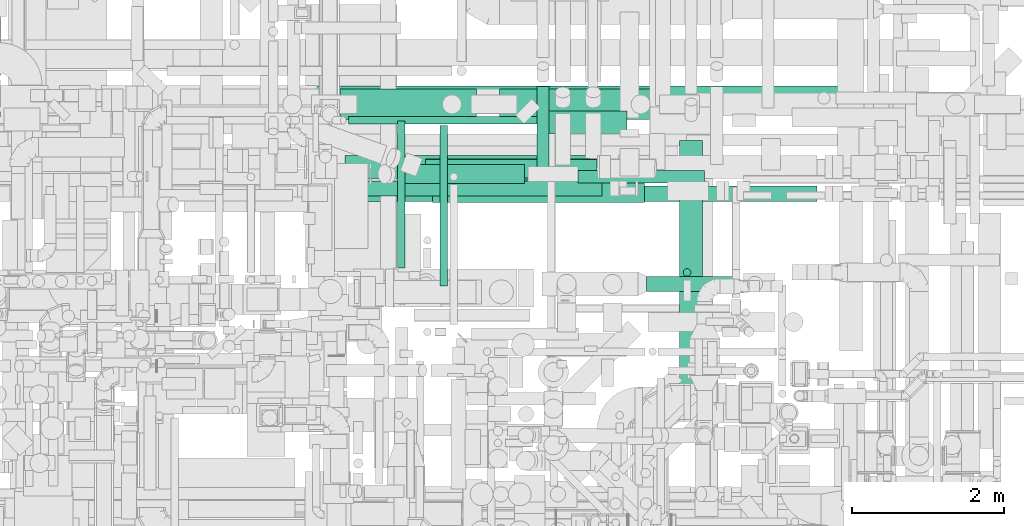
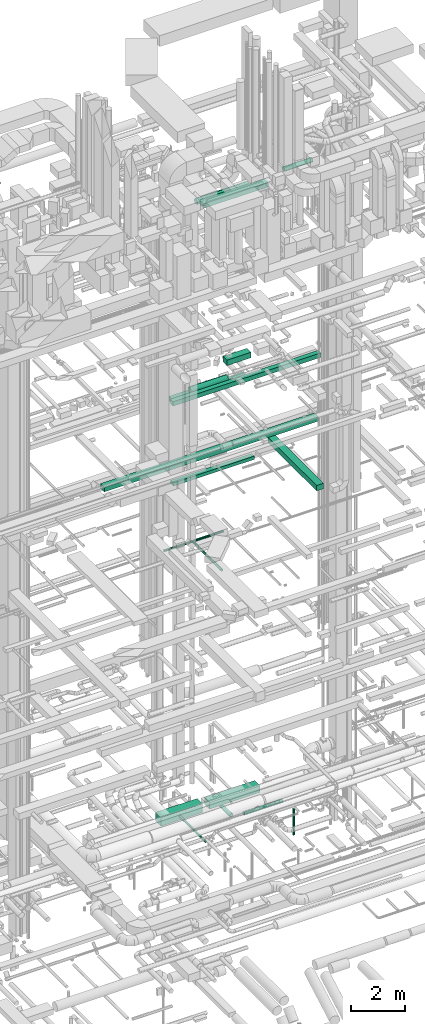
# One storey, part 59 of 337: 18 flow segments.
"""IFC2X3 building model written with IfcOpenShell, lengths in millimetres."""

from ifc_helpers import new_model, entity, si_unit, converted_unit, derived_unit, direction, frame, origin, origin_2d_with_axis, place, context, subcontext, project, spatial, rectangle, circle, extrude, type_object, element, save


model = new_model("IFC2X3")

# Units and contexts
model_context = context("Model", 3, precision=0.01, world=origin(), true_north=direction((6.12303176911189e-17, 1.0)))
body_context = subcontext(model_context, "Body", "Model", "MODEL_VIEW")
ifc_project = project(units=[si_unit("LENGTHUNIT", "METRE", prefix="MILLI"), si_unit("AREAUNIT", "SQUARE_METRE"), si_unit("VOLUMEUNIT", "CUBIC_METRE"), converted_unit("PLANEANGLEUNIT", "DEGREE", entity("IfcRatioMeasure", 0.0174532925199433), si_unit("PLANEANGLEUNIT", "RADIAN"), dimensions=[0, 0, 0, 0, 0, 0, 0]), si_unit("MASSUNIT", "GRAM", prefix="KILO"), derived_unit("MASSDENSITYUNIT", [(si_unit("MASSUNIT", "GRAM", prefix="KILO"), 1), (si_unit("LENGTHUNIT", "METRE"), -3)]), derived_unit("MOMENTOFINERTIAUNIT", [(si_unit("LENGTHUNIT", "METRE"), 4)]), si_unit("TIMEUNIT", "SECOND"), si_unit("FREQUENCYUNIT", "HERTZ"), si_unit("THERMODYNAMICTEMPERATUREUNIT", "DEGREE_CELSIUS"), derived_unit("THERMALTRANSMITTANCEUNIT", [(si_unit("MASSUNIT", "GRAM", prefix="KILO"), 1), (si_unit("THERMODYNAMICTEMPERATUREUNIT", "KELVIN"), -1), (si_unit("TIMEUNIT", "SECOND"), -3)]), derived_unit("VOLUMETRICFLOWRATEUNIT", [(si_unit("LENGTHUNIT", "METRE"), 3), (si_unit("TIMEUNIT", "SECOND"), -1)]), derived_unit("MASSFLOWRATEUNIT", [(si_unit("MASSUNIT", "GRAM", prefix="KILO"), 1), (si_unit("TIMEUNIT", "SECOND"), -1)]), derived_unit("ROTATIONALFREQUENCYUNIT", [(si_unit("TIMEUNIT", "SECOND"), -1)]), si_unit("ELECTRICCURRENTUNIT", "AMPERE"), si_unit("ELECTRICVOLTAGEUNIT", "VOLT"), si_unit("POWERUNIT", "WATT"), si_unit("FORCEUNIT", "NEWTON", prefix="KILO"), si_unit("ILLUMINANCEUNIT", "LUX"), si_unit("LUMINOUSFLUXUNIT", "LUMEN"), si_unit("LUMINOUSINTENSITYUNIT", "CANDELA"), derived_unit("USERDEFINED", [(si_unit("MASSUNIT", "GRAM", prefix="KILO"), -1), (si_unit("LENGTHUNIT", "METRE"), -2), (si_unit("TIMEUNIT", "SECOND"), 3), (si_unit("LUMINOUSFLUXUNIT", "LUMEN"), 1)]), derived_unit("LINEARVELOCITYUNIT", [(si_unit("LENGTHUNIT", "METRE"), 1), (si_unit("TIMEUNIT", "SECOND"), -1)]), si_unit("PRESSUREUNIT", "PASCAL"), derived_unit("USERDEFINED", [(si_unit("LENGTHUNIT", "METRE"), -2), (si_unit("MASSUNIT", "GRAM", prefix="KILO"), 1), (si_unit("TIMEUNIT", "SECOND"), -2)]), derived_unit("LINEARFORCEUNIT", [(si_unit("MASSUNIT", "GRAM", prefix="KILO"), 1), (si_unit("LENGTHUNIT", "METRE"), 1), (si_unit("TIMEUNIT", "SECOND"), -2), (si_unit("LENGTHUNIT", "METRE"), -1)]), derived_unit("PLANARFORCEUNIT", [(si_unit("MASSUNIT", "GRAM", prefix="KILO"), 1), (si_unit("LENGTHUNIT", "METRE"), 1), (si_unit("TIMEUNIT", "SECOND"), -2), (si_unit("LENGTHUNIT", "METRE"), -2)])], contexts=[model_context])

# Site, building, storey
site_placement = place(None, origin())
site = spatial("IfcSite", under=ifc_project, at=site_placement, CompositionType="ELEMENT")
building_placement = place(site_placement, origin())
building = spatial("IfcBuilding", under=site, at=building_placement, CompositionType="ELEMENT")
storey_placement = place(building_placement, origin())
storey = spatial("IfcBuildingStorey", under=building, at=storey_placement, CompositionType="ELEMENT", Elevation=0.0)

# Flow segments
duct_segment_type_1 = type_object("IfcDuctSegmentType", PredefinedType="NOTDEFINED")
flow_segment_1_placement = place(storey_placement, frame((53521.17, 15148.96, -1050.0)))
element("IfcFlowSegment", 1, at=flow_segment_1_placement, inside=storey, type_object=duct_segment_type_1, context=body_context, shape_type="SweptSolid", body=[
    extrude(rectangle(XDim=1794.33030025006, YDim=400.0, at=origin_2d_with_axis()), frame((897.17, 200.0, 0.0)), (0.0, 0.0, 1.0), 400.0),
])
flow_segment_2_placement = place(storey_placement, frame((55615.5, 15148.96, -1000.0)))
element("IfcFlowSegment", 2, at=flow_segment_2_placement, inside=storey, type_object=duct_segment_type_1, context=body_context, shape_type="SweptSolid", body=[
    extrude(rectangle(XDim=2175.17176975001, YDim=400.0, at=origin_2d_with_axis()), frame((1087.59, 200.0, 0.0)), (0.0, 0.0, 1.0), 300.0),
])
flow_segment_3_placement = place(storey_placement, frame((51169.3, 15290.0, 14900.0)))
element("IfcFlowSegment", 3, at=flow_segment_3_placement, inside=storey, type_object=duct_segment_type_1, context=body_context, shape_type="SweptSolid", body=[
    extrude(rectangle(XDim=9217.88273742502, YDim=300.000000000001, at=origin_2d_with_axis()), frame((4608.94, 150.0, 0.0), z_axis=(0.0, 0.0, 1.0), x_axis=(-1.0, 0.0, 0.0)), (0.0, 0.0, 1.0), 200.000000000002),
])
flow_segment_4_placement = place(storey_placement, frame((53470.19, 14143.91, 15050.0)))
element("IfcFlowSegment", 4, at=flow_segment_4_placement, inside=storey, type_object=duct_segment_type_1, context=body_context, shape_type="SweptSolid", body=[
    extrude(rectangle(XDim=3488.48123509233, YDim=200.0, at=origin_2d_with_axis()), frame((1744.24, 100.0, 0.0), z_axis=(0.0, 0.0, 1.0), x_axis=(-1.0, 0.0, 0.0)), (0.0, 0.0, 1.0), 150.000000000001),
])
flow_segment_5_placement = place(storey_placement, frame((57977.28, 11265.63, 15000.0)))
element("IfcFlowSegment", 5, at=flow_segment_5_placement, inside=storey, type_object=duct_segment_type_1, context=body_context, shape_type="SweptSolid", body=[
    extrude(rectangle(XDim=3607.45757233171, YDim=300.000000000001, at=origin_2d_with_axis()), frame((150.0, 1803.73, 0.0), z_axis=(0.0, 0.0, 1.0), x_axis=(0.0, -1.0, 0.0)), (0.0, 0.0, 1.0), 249.999999999999),
])
flow_segment_6_placement = place(storey_placement, frame((53417.53, 14075.53, 18750.0)))
element("IfcFlowSegment", 6, at=flow_segment_6_placement, inside=storey, type_object=duct_segment_type_1, context=body_context, shape_type="SweptSolid", body=[
    extrude(rectangle(XDim=6362.55047582083, YDim=200.0, at=origin_2d_with_axis()), frame((3181.28, 100.0, 0.0)), (0.0, 0.0, 1.0), 200.000000000002),
])
flow_segment_7_placement = place(storey_placement, frame((56252.92, 14964.34, 19059.58)))
element("IfcFlowSegment", 7, at=flow_segment_7_placement, inside=storey, type_object=duct_segment_type_1, context=body_context, shape_type="SweptSolid", body=[
    extrude(rectangle(XDim=1036.51344696079, YDim=300.000000000001, at=origin_2d_with_axis()), frame((518.26, 150.0, 0.0), z_axis=(0.0, 0.0, 1.0), x_axis=(-1.0, 0.0, 0.0)), (0.0, 0.0, 1.0), 249.999999999999),
])
flow_segment_8_placement = place(storey_placement, frame((53590.57, 14375.32, 18577.01)))
element("IfcFlowSegment", 8, at=flow_segment_8_placement, inside=storey, type_object=duct_segment_type_1, context=body_context, shape_type="SweptSolid", body=[
    extrude(rectangle(XDim=3205.80194846593, YDim=299.999999999999, at=origin_2d_with_axis()), frame((1602.9, 150.0, 0.0), z_axis=(0.0, 0.0, 1.0), x_axis=(-1.0, 0.0, 0.0)), (0.0, 0.0, 1.0), 199.999999999998),
])
flow_segment_9_placement = place(storey_placement, frame((54735.82, 14062.02, 27300.0)))
element("IfcFlowSegment", 9, at=flow_segment_9_placement, inside=storey, type_object=duct_segment_type_1, context=body_context, shape_type="SweptSolid", body=[
    extrude(rectangle(XDim=2780.00000000006, YDim=300.000000000001, at=origin_2d_with_axis()), frame((1390.0, 150.0, 0.0)), (0.0, 0.0, 1.0), 199.999999999998),
])
duct_segment_type_2 = type_object("IfcDuctSegmentType", PredefinedType="NOTDEFINED")
flow_segment_10_placement = place(storey_placement, frame((54272.91, 13205.52, -901.6)))
element("IfcFlowSegment", 10, at=flow_segment_10_placement, inside=storey, type_object=duct_segment_type_2, context=body_context, shape_type="SweptSolid", body=[
    extrude(circle(Radius=50.0, at=origin_2d_with_axis()), frame((51.6, 0.0, 51.6), z_axis=(0.0, 1.0, 0.0), x_axis=(1.0, 0.0, 0.0)), (0.0, 0.0, 1.0), 1923.43979000035),
])
flow_segment_11_placement = place(storey_placement, frame((58022.61, 13092.41, -1800.0)))
element("IfcFlowSegment", 11, at=flow_segment_11_placement, inside=storey, type_object=duct_segment_type_2, context=body_context, shape_type="SweptSolid", body=[
    extrude(circle(Radius=50.0, at=origin_2d_with_axis()), frame((51.6, 51.6, 0.0)), (0.0, 0.0, 1.0), 1180.00000000002),
])
flow_segment_12_placement = place(storey_placement, frame((56647.07, 14316.8, -1181.6)))
element("IfcFlowSegment", 12, at=flow_segment_12_placement, inside=storey, type_object=duct_segment_type_2, context=body_context, shape_type="SweptSolid", body=[
    extrude(circle(Radius=80.0, at=origin_2d_with_axis()), frame((0.0, 81.6, 81.6), z_axis=(1.0, 0.0, 0.0), x_axis=(0.0, 1.0, 0.0)), (0.0, 0.0, 1.0), 1657.06978666614),
])
flow_segment_13_placement = place(storey_placement, frame((56103.94, 14518.39, -1181.6)))
element("IfcFlowSegment", 13, at=flow_segment_13_placement, inside=storey, type_object=duct_segment_type_2, context=body_context, shape_type="SweptSolid", body=[
    extrude(circle(Radius=80.0, at=origin_2d_with_axis()), frame((81.6, 0.0, 81.6), z_axis=(0.0, 1.0, 0.0), x_axis=(1.0, 0.0, 0.0)), (0.0, 0.0, 1.0), 1063.21305852543),
])
flow_segment_14_placement = place(storey_placement, frame((54830.76, 12963.29, 11398.4)))
element("IfcFlowSegment", 14, at=flow_segment_14_placement, inside=storey, type_object=duct_segment_type_2, context=body_context, shape_type="SweptSolid", body=[
    extrude(circle(Radius=50.0, at=origin_2d_with_axis()), frame((51.6, 0.0, 51.6), z_axis=(0.0, 1.0, 0.0), x_axis=(-1.0, 0.0, 0.0)), (0.0, 0.0, 1.0), 2105.00000000006),
])
flow_segment_15_placement = place(storey_placement, frame((53636.31, 15086.69, 11398.4)))
element("IfcFlowSegment", 15, at=flow_segment_15_placement, inside=storey, type_object=duct_segment_type_2, context=body_context, shape_type="SweptSolid", body=[
    extrude(circle(Radius=50.0, at=origin_2d_with_axis()), frame((0.0, 51.6, 51.6), z_axis=(1.0, 0.0, 0.0), x_axis=(0.0, 1.0, 0.0)), (0.0, 0.0, 1.0), 2559.29864376273),
])
flow_segment_16_placement = place(storey_placement, frame((54338.59, 14308.92, 18823.4)))
element("IfcFlowSegment", 16, at=flow_segment_16_placement, inside=storey, type_object=duct_segment_type_2, context=body_context, shape_type="SweptSolid", body=[
    extrude(circle(Radius=125.0, at=origin_2d_with_axis()), frame((0.0, 126.6, 126.6), z_axis=(1.0, 0.0, 0.0), x_axis=(0.0, 1.0, 0.0)), (0.0, 0.0, 1.0), 1601.44660940674),
])
flow_segment_17_placement = place(storey_placement, frame((54646.87, 14378.71, 27248.4)))
element("IfcFlowSegment", 17, at=flow_segment_17_placement, inside=storey, type_object=duct_segment_type_2, context=body_context, shape_type="SweptSolid", body=[
    extrude(circle(Radius=125.0, at=origin_2d_with_axis()), frame((0.0, 126.6, 126.6), z_axis=(1.0, 0.0, 0.0), x_axis=(0.0, -1.0, 0.0)), (0.0, 0.0, 1.0), 2244.5398187904),
])
flow_segment_18_placement = place(storey_placement, frame((57542.66, 12892.42, 28648.4)))
element("IfcFlowSegment", 18, at=flow_segment_18_placement, inside=storey, type_object=duct_segment_type_2, context=body_context, shape_type="SweptSolid", body=[
    extrude(circle(Radius=100.0, at=origin_2d_with_axis()), frame((0.0, 101.6, 101.6), z_axis=(1.0, 0.0, 0.0), x_axis=(0.0, -1.0, 0.0)), (0.0, 0.0, 1.0), 1220.6435447108),
])

save(model, "model.ifc")
